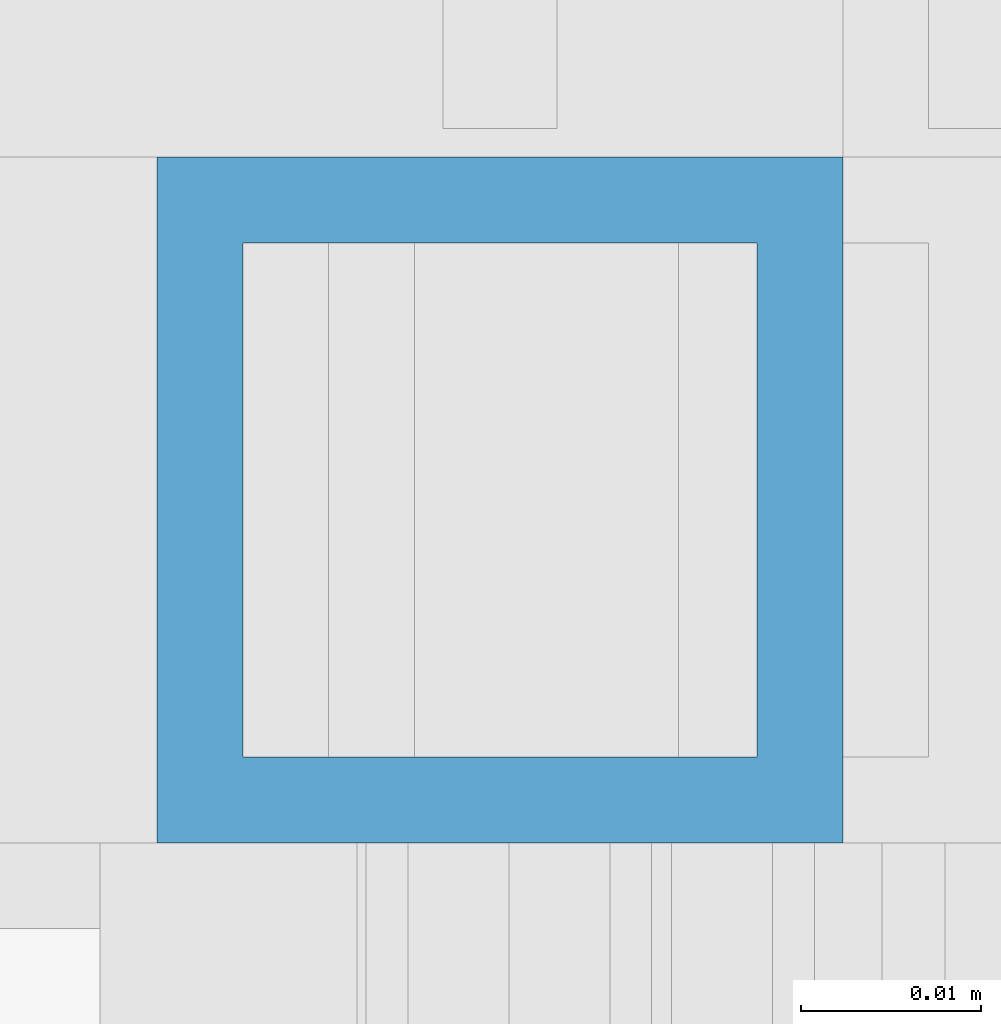
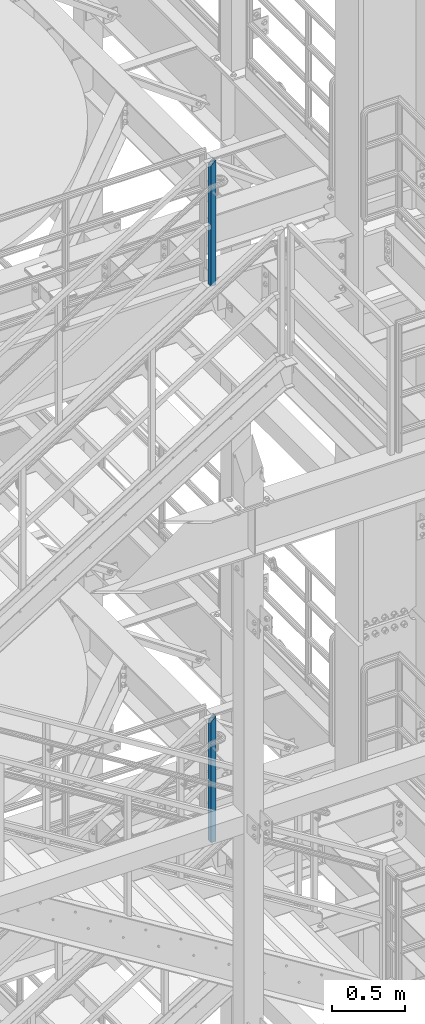
# One storey, part 649 of 1876: 2 columns, 2 elements without a shape of their own.
"""IFC2X3 building model written with IfcOpenShell, lengths in millimetres."""

from ifc_helpers import new_model, si_unit, frame, origin_with_axes, place, context, subcontext, project, spatial, faceted_brep, material, type_object, element, aggregate, save


model = new_model("IFC2X3")

# Units and contexts
model_context = context("Model", 3, precision=1e-05, world=origin_with_axes())
body_context = subcontext(model_context, "Body", "Model", "MODEL_VIEW")
ifc_project = project(units=[si_unit("LENGTHUNIT", "METRE", prefix="MILLI"), si_unit("AREAUNIT", "SQUARE_METRE"), si_unit("VOLUMEUNIT", "CUBIC_METRE"), si_unit("MASSUNIT", "GRAM", prefix="KILO"), si_unit("TIMEUNIT", "SECOND"), si_unit("PLANEANGLEUNIT", "RADIAN"), si_unit("SOLIDANGLEUNIT", "STERADIAN"), si_unit("THERMODYNAMICTEMPERATUREUNIT", "DEGREE_CELSIUS"), si_unit("LUMINOUSINTENSITYUNIT", "LUMEN")], contexts=[model_context])

# Site, building, storey
site_placement = place(None, origin_with_axes())
site = spatial("IfcSite", under=ifc_project, at=site_placement, CompositionType="ELEMENT")
building_placement = place(site_placement, origin_with_axes())
building = spatial("IfcBuilding", under=site, at=building_placement, Name="Undefined", CompositionType="ELEMENT")
storey_placement = place(building_placement, origin_with_axes())
storey = spatial("IfcBuildingStorey", under=building, at=storey_placement, Name="Undefined", CompositionType="ELEMENT", Elevation=0.0)

# Assembly, column
assembly_1_placement = place(storey_placement, origin_with_axes())
assembly_1 = element("IfcElementAssembly", 1, at=assembly_1_placement, inside=storey, Name="RAIL", AssemblyPlace="NOTDEFINED", PredefinedType="RIGID_FRAME")
ifc_material = material()
column_type = type_object("IfcColumnType", Name="HSS1-1/2X1-1/2X3/16", PredefinedType="NOTDEFINED")
column_1_placement = place(assembly_1_placement, frame((6137.27499995292, -4781.55000114554, 13335.0000000052), z_axis=(-1.0, 0.0, 0.0), x_axis=(0.0, 0.0, 1.0)))
column_1 = element("IfcColumn", 2, at=column_1_placement, type_object=column_type, material=ifc_material, Name="POST", ObjectType="HSS1-1/2X1-1/2X3/16", context=body_context, shape_type="Brep", body=[
    faceted_brep([(1022.350000765, -19.0499992349996, 19.0499992349996), (1022.350000765, 19.0499992349996, 19.0499992349996), (9.52499999771135, 19.0499992349996, 19.0499992350001), (9.52499999771135, -19.0499992420619, 19.0499992350001), (1060.449999235, -19.0499992349996, -19.0499992349996), (9.52499999771135, -19.0499992349996, -19.0499992350001), (1060.449999235, 19.0499992349996, -19.0499992349996), (9.52499999771135, 19.0499992349996, -19.0499992350001), (1027.112500574, -14.2874994260001, 14.2874994260001), (1027.112500574, 14.2874994260001, 14.2874994260001), (1055.687499426, 14.2874994260001, -14.2874994260001), (1055.687499426, -14.2874994260001, -14.2874994260001), (9.52499999771135, -14.2874994260001, 14.2874994260001), (9.52499999771135, 14.2874994260001, 14.2874994260001), (9.52499999771135, 14.2874994260001, -14.2874994260001), (9.52499999771135, -14.2874994260001, -14.2874994260001)], [[[0, 1, 2, 3]], [[4, 0, 3, 5]], [[6, 4, 5, 7]], [[1, 6, 7, 2]], [[0, 4, 6, 1], [8, 9, 10, 11]], [[9, 8, 12, 13]], [[10, 9, 13, 14]], [[11, 10, 14, 15]], [[8, 11, 15, 12]], [[7, 5, 3, 2], [14, 13, 12, 15]]]),
])
aggregate(assembly_1, [column_1])

assembly_2_placement = place(storey_placement, origin_with_axes())
assembly_2 = element("IfcElementAssembly", 3, at=assembly_2_placement, inside=storey, Name="RAIL", AssemblyPlace="NOTDEFINED", PredefinedType="RIGID_FRAME")
column_2_placement = place(assembly_2_placement, frame((6137.27499960753, -4781.55000114554, 18008.6000004074), z_axis=(-1.0, 0.0, 0.0), x_axis=(0.0, 0.0, 1.0)))
column_2 = element("IfcColumn", 4, at=column_2_placement, type_object=column_type, material=ifc_material, Name="POST", ObjectType="HSS1-1/2X1-1/2X3/16", context=body_context, shape_type="Brep", body=[
    faceted_brep([(1022.350000765, -19.0499992349996, 19.0499992349996), (1022.350000765, 19.0499992349996, 19.0499992349996), (9.58492796205246, 19.0499992349996, 19.0499992349996), (9.58492796205246, -19.0499992349996, 19.0499992349996), (1060.449999235, -19.0499992349996, -19.0499992349996), (9.58492796205246, -19.0499992349996, -19.0499992349996), (1060.449999235, 19.0499992349996, -19.0499992349996), (9.58492796205246, 19.0499992349996, -19.0499992349996), (1027.112500574, -14.2874994260001, 14.2874994260001), (1027.112500574, 14.2874994260001, 14.2874994260001), (1055.687499426, 14.2874994260001, -14.2874994260001), (1055.687499426, -14.2874994260001, -14.2874994260001), (9.58492796205246, -14.2874994260001, 14.2874994260001), (9.58492796205246, 14.2874994260001, 14.2874994260001), (9.58492796205246, 14.2874994260001, -14.2874994260001), (9.58492796205246, -14.2874994260001, -14.2874994260001)], [[[0, 1, 2, 3]], [[4, 0, 3, 5]], [[6, 4, 5, 7]], [[1, 6, 7, 2]], [[0, 4, 6, 1], [8, 9, 10, 11]], [[9, 8, 12, 13]], [[10, 9, 13, 14]], [[11, 10, 14, 15]], [[8, 11, 15, 12]], [[7, 5, 3, 2], [14, 13, 12, 15]]]),
])
aggregate(assembly_2, [column_2])

save(model, "model.ifc")
